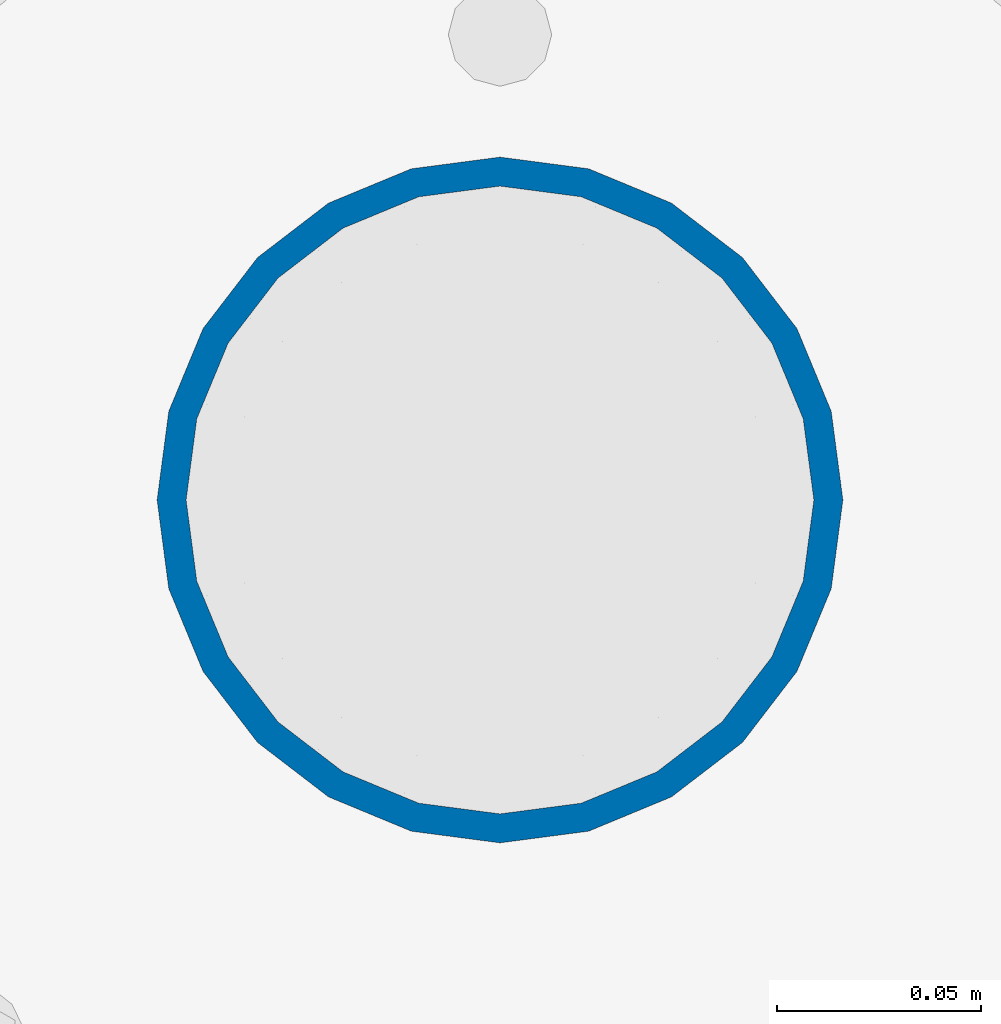
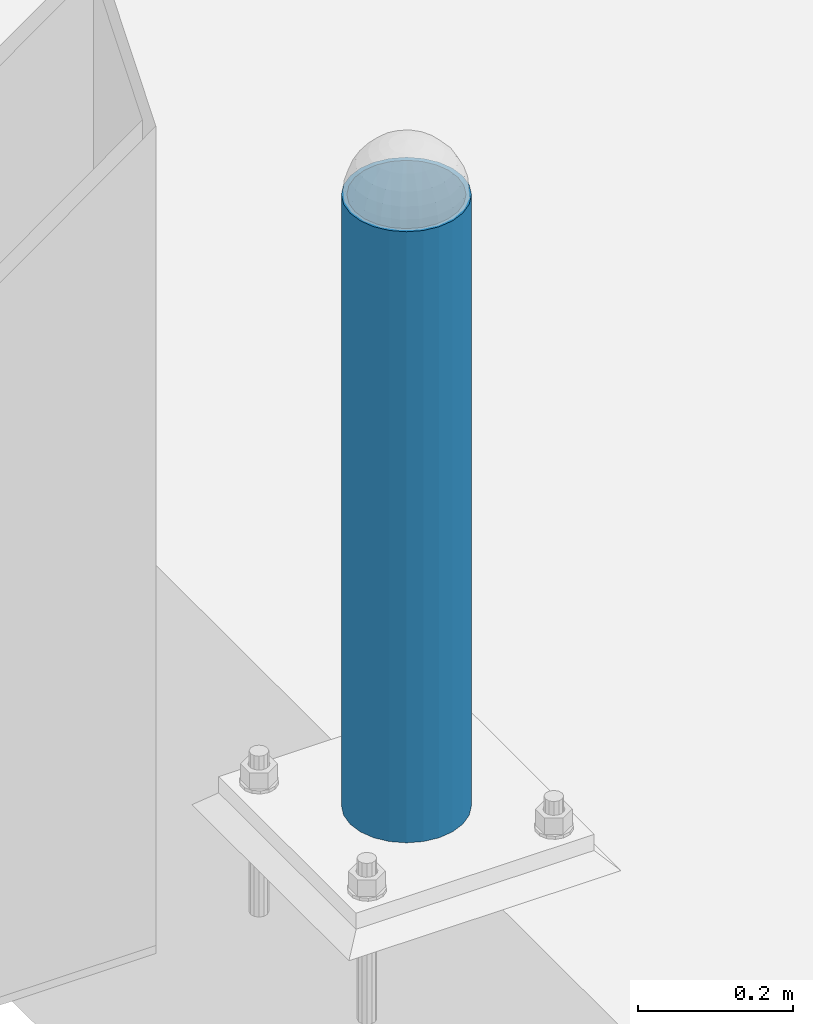
# One storey, part 1464 of 3843: 1 column, 1 element without a shape of its own.
"""IFC2X3 building model written with IfcOpenShell, lengths in millimetres."""

from ifc_helpers import new_model, si_unit, frame, origin_with_axes, place, context, subcontext, project, spatial, faceted_brep, material, type_object, element, aggregate, save


model = new_model("IFC2X3")

# Units and contexts
model_context = context("Model", 3, precision=1e-05, world=origin_with_axes())
body_context = subcontext(model_context, "Body", "Model", "MODEL_VIEW")
ifc_project = project(units=[si_unit("LENGTHUNIT", "METRE", prefix="MILLI"), si_unit("AREAUNIT", "SQUARE_METRE"), si_unit("VOLUMEUNIT", "CUBIC_METRE"), si_unit("MASSUNIT", "GRAM", prefix="KILO"), si_unit("TIMEUNIT", "SECOND"), si_unit("PLANEANGLEUNIT", "RADIAN"), si_unit("SOLIDANGLEUNIT", "STERADIAN"), si_unit("THERMODYNAMICTEMPERATUREUNIT", "DEGREE_CELSIUS"), si_unit("LUMINOUSINTENSITYUNIT", "LUMEN")], contexts=[model_context])

# Site, building, storey
site_placement = place(None, origin_with_axes())
site = spatial("IfcSite", under=ifc_project, at=site_placement, CompositionType="ELEMENT")
building_placement = place(site_placement, origin_with_axes())
building = spatial("IfcBuilding", under=site, at=building_placement, Name="Undefined", CompositionType="ELEMENT")
storey_placement = place(building_placement, origin_with_axes())
storey = spatial("IfcBuildingStorey", under=building, at=storey_placement, Name="Undefined", CompositionType="ELEMENT", Elevation=0.0)

# Assembly, column
assembly_placement = place(storey_placement, origin_with_axes())
assembly = element("IfcElementAssembly", 1, at=assembly_placement, inside=storey, Name="PIPE_BOLLARD", AssemblyPlace="NOTDEFINED", PredefinedType="RIGID_FRAME")
ifc_material = material()
column_type = type_object("IfcColumnType", Name="PIPE6SCH40", PredefinedType="NOTDEFINED")
column_placement = place(assembly_placement, frame((42035.776550293, 30099.7152178551, 30480.0), z_axis=(-1.0, 0.0, 0.0), x_axis=(0.0, 0.0, 1.0)))
column = element("IfcColumn", 2, at=column_placement, type_object=column_type, material=ifc_material, Name="PIPE_BOLLARD", ObjectType="PIPE6SCH40", context=body_context, shape_type="Brep", body=[
    faceted_brep([(50.7999999999993, -77.0890000000072, 0.0), (50.7999999999993, -74.4622560228017, 19.9521013679114), (1016.0, -74.4622560228017, 19.9521013679114), (1016.0, -77.0890000000072, 0.0), (50.7999999999993, -66.7610323523404, 38.5445000000036), (1016.0, -66.7610323523404, 38.5445000000036), (50.7999999999993, -54.5101546548831, 54.5101546548904), (1016.0, -54.5101546548831, 54.5101546548904), (50.7999999999993, -38.5445000000036, 66.7610323523404), (1016.0, -38.5445000000036, 66.7610323523404), (50.7999999999993, -19.9521013679041, 74.4622560227945), (1016.0, -19.9521013679041, 74.4622560227945), (50.7999999999993, 0.0, 77.0889999999999), (1016.0, 0.0, 77.0889999999999), (50.7999999999993, 19.9521013679041, 74.4622560227945), (1016.0, 19.9521013679041, 74.4622560227945), (50.7999999999993, 38.5445000000036, 66.7610323523404), (1016.0, 38.5445000000036, 66.7610323523404), (50.7999999999993, 54.5101546548831, 54.5101546548904), (1016.0, 54.5101546548831, 54.5101546548904), (50.7999999999993, 66.7610323523404, 38.5445000000036), (1016.0, 66.7610323523404, 38.5445000000036), (50.7999999999993, 74.4622560228017, 19.9521013679114), (1016.0, 74.4622560228017, 19.9521013679114), (50.7999999999993, 77.0890000000072, 0.0), (1016.0, 77.0890000000072, 0.0), (50.7999999999993, 74.4622560228017, -19.9521013679114), (1016.0, 74.4622560228017, -19.9521013679114), (50.7999999999993, 66.7610323523404, -38.5445000000036), (1016.0, 66.7610323523404, -38.5445000000036), (50.7999999999993, 54.5101546548831, -54.5101546548904), (1016.0, 54.5101546548831, -54.5101546548904), (50.7999999999993, 38.5445000000036, -66.7610323523404), (1016.0, 38.5445000000036, -66.7610323523404), (50.7999999999993, 19.9521013679041, -74.4622560227945), (1016.0, 19.9521013679041, -74.4622560227945), (50.7999999999993, 0.0, -77.0889999999999), (1016.0, 0.0, -77.0889999999999), (50.7999999999993, -19.9521013679041, -74.4622560227945), (1016.0, -19.9521013679041, -74.4622560227945), (50.7999999999993, -38.5445000000036, -66.7610323523404), (1016.0, -38.5445000000036, -66.7610323523404), (50.7999999999993, -54.5101546548831, -54.5101546548904), (1016.0, -54.5101546548831, -54.5101546548904), (50.7999999999993, -66.7610323523404, -38.5445000000036), (1016.0, -66.7610323523404, -38.5445000000036), (50.7999999999993, -74.4622560228017, -19.9521013679114), (1016.0, -74.4622560228017, -19.9521013679114), (50.7999999999993, -84.2010000000009, 0.0), (50.7999999999993, -81.3319204993604, -21.7928224166753), (1016.0, -81.3319204993604, -21.7928224166753), (1016.0, -84.2010000000009, 0.0), (50.7999999999993, -72.9202050240565, -42.1005000000005), (1016.0, -72.9202050240565, -42.1005000000005), (50.7999999999993, -59.5390980826924, -59.5390980826851), (1016.0, -59.5390980826924, -59.5390980826851), (50.7999999999993, -42.1005000000005, -72.9202050240565), (1016.0, -42.1005000000005, -72.9202050240565), (50.7999999999993, -21.7928224166826, -81.3319204993677), (1016.0, -21.7928224166826, -81.3319204993677), (50.7999999999993, 0.0, -84.2010000000009), (1016.0, 0.0, -84.2010000000009), (50.7999999999993, 21.7928224166826, -81.3319204993677), (1016.0, 21.7928224166826, -81.3319204993677), (50.7999999999993, 42.1005000000005, -72.9202050240565), (1016.0, 42.1005000000005, -72.9202050240565), (50.7999999999993, 59.5390980826924, -59.5390980826851), (1016.0, 59.5390980826924, -59.5390980826851), (50.7999999999993, 72.9202050240565, -42.1005000000005), (1016.0, 72.9202050240565, -42.1005000000005), (50.7999999999993, 81.3319204993604, -21.7928224166753), (1016.0, 81.3319204993604, -21.7928224166753), (50.7999999999993, 84.2010000000009, 0.0), (1016.0, 84.2010000000009, 0.0), (50.7999999999993, 81.3319204993604, 21.7928224166753), (1016.0, 81.3319204993604, 21.7928224166753), (50.7999999999993, 72.9202050240565, 42.1005000000005), (1016.0, 72.9202050240565, 42.1005000000005), (50.7999999999993, 59.5390980826924, 59.5390980826851), (1016.0, 59.5390980826924, 59.5390980826851), (50.7999999999993, 42.1005000000005, 72.9202050240565), (1016.0, 42.1005000000005, 72.9202050240565), (50.7999999999993, 21.7928224166826, 81.3319204993677), (1016.0, 21.7928224166826, 81.3319204993677), (50.7999999999993, 0.0, 84.2010000000009), (1016.0, 0.0, 84.2010000000009), (50.7999999999993, -21.7928224166826, 81.3319204993677), (1016.0, -21.7928224166826, 81.3319204993677), (50.7999999999993, -42.1005000000005, 72.9202050240565), (1016.0, -42.1005000000005, 72.9202050240565), (50.7999999999993, -59.5390980826924, 59.5390980826851), (1016.0, -59.5390980826924, 59.5390980826851), (50.7999999999993, -72.9202050240565, 42.1005000000005), (1016.0, -72.9202050240565, 42.1005000000005), (50.7999999999993, -81.3319204993604, 21.7928224166753), (1016.0, -81.3319204993604, 21.7928224166753)], [[[0, 1, 2, 3]], [[1, 4, 5, 2]], [[4, 6, 7, 5]], [[6, 8, 9, 7]], [[8, 10, 11, 9]], [[10, 12, 13, 11]], [[12, 14, 15, 13]], [[14, 16, 17, 15]], [[16, 18, 19, 17]], [[18, 20, 21, 19]], [[20, 22, 23, 21]], [[22, 24, 25, 23]], [[24, 26, 27, 25]], [[26, 28, 29, 27]], [[28, 30, 31, 29]], [[30, 32, 33, 31]], [[32, 34, 35, 33]], [[34, 36, 37, 35]], [[36, 38, 39, 37]], [[38, 40, 41, 39]], [[40, 42, 43, 41]], [[42, 44, 45, 43]], [[44, 46, 47, 45]], [[46, 0, 3, 47]], [[48, 49, 50, 51]], [[49, 52, 53, 50]], [[52, 54, 55, 53]], [[54, 56, 57, 55]], [[56, 58, 59, 57]], [[58, 60, 61, 59]], [[60, 62, 63, 61]], [[62, 64, 65, 63]], [[64, 66, 67, 65]], [[66, 68, 69, 67]], [[68, 70, 71, 69]], [[70, 72, 73, 71]], [[72, 74, 75, 73]], [[74, 76, 77, 75]], [[76, 78, 79, 77]], [[78, 80, 81, 79]], [[80, 82, 83, 81]], [[82, 84, 85, 83]], [[84, 86, 87, 85]], [[86, 88, 89, 87]], [[88, 90, 91, 89]], [[90, 92, 93, 91]], [[92, 94, 95, 93]], [[94, 48, 51, 95]], [[53, 55, 57, 59, 61, 63, 65, 67, 69, 71, 73, 75, 77, 79, 81, 83, 85, 87, 89, 91, 93, 95, 51, 50], [5, 7, 9, 11, 13, 15, 17, 19, 21, 23, 25, 27, 29, 31, 33, 35, 37, 39, 41, 43, 45, 47, 3, 2]], [[94, 92, 90, 88, 86, 84, 82, 80, 78, 76, 74, 72, 70, 68, 66, 64, 62, 60, 58, 56, 54, 52, 49, 48], [46, 44, 42, 40, 38, 36, 34, 32, 30, 28, 26, 24, 22, 20, 18, 16, 14, 12, 10, 8, 6, 4, 1, 0]]]),
])
aggregate(assembly, [column])

save(model, "model.ifc")
